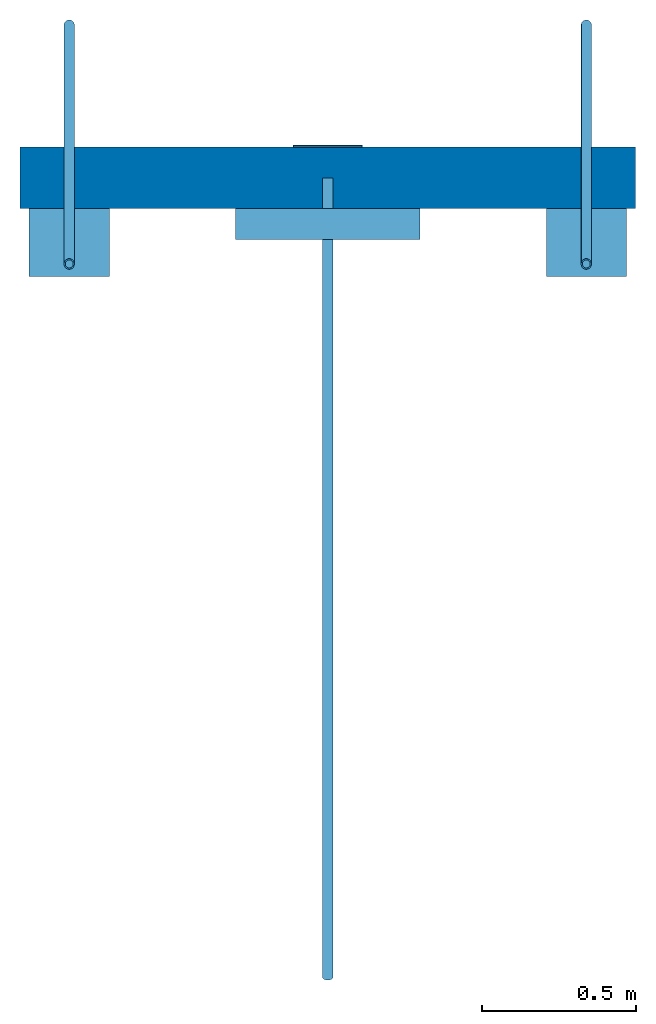
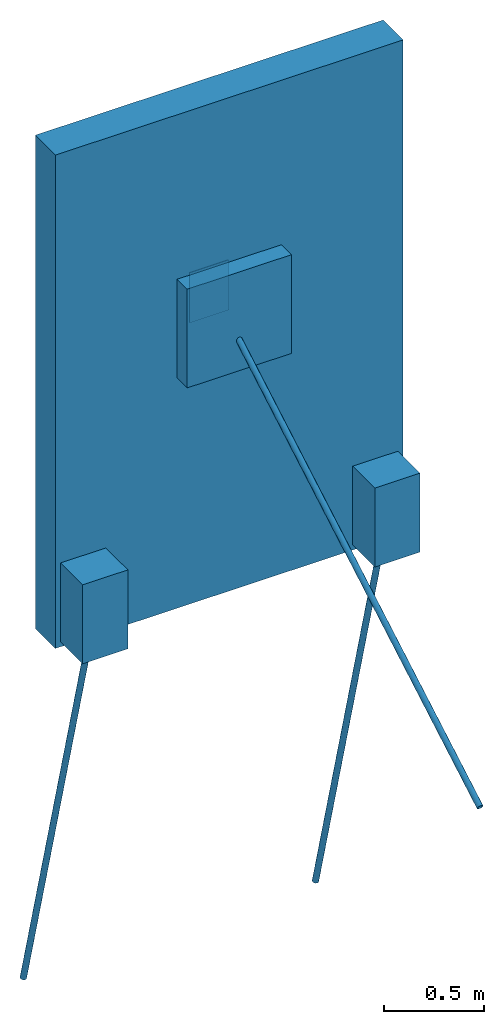
# One storey: 4 walls, 3 beams, 1 column.
"""IFC4 building model written with IfcOpenShell, lengths in metres."""

from ifc_helpers import new_model, entity, si_unit, converted_unit, derived_unit, frame, frame_2d, origin, origin_with_axes, origin_2d_with_axis, place, context, subcontext, project, spatial, polyline, rectangle, outline, extrude, clip, halfspace, material, layer, layer_set, layer_usage, element, save


model = new_model("IFC4")

# Units and contexts
model_context = context("Model", 3, precision=1e-05, world=origin())
body_context = subcontext(model_context, "Body", "Model", "MODEL_VIEW")
ifc_project = project(units=[si_unit("LENGTHUNIT", "METRE"), si_unit("AREAUNIT", "SQUARE_METRE"), si_unit("VOLUMEUNIT", "CUBIC_METRE"), si_unit("MASSUNIT", "GRAM", prefix="KILO"), converted_unit("PLANEANGLEUNIT", "DEGREE", entity("IfcPlaneAngleMeasure", 0.0174532925199433), si_unit("PLANEANGLEUNIT", "RADIAN"), dimensions=[0, 0, 0, 0, 0, 0, 0]), derived_unit("THERMALTRANSMITTANCEUNIT", [(si_unit("POWERUNIT", "WATT"), 1), (si_unit("THERMODYNAMICTEMPERATUREUNIT", "KELVIN"), -1), (si_unit("LENGTHUNIT", "METRE"), -2)]), derived_unit("VOLUMETRICFLOWRATEUNIT", [(si_unit("LENGTHUNIT", "METRE"), 3), (converted_unit("TIMEUNIT", "hour", entity("IfcTimeMeasure", 3600.0), si_unit("TIMEUNIT", "SECOND"), dimensions=[0, 0, 1, 0, 0, 0, 0]), -1), (si_unit("LENGTHUNIT", "METRE"), -1)])], contexts=[model_context])

# Site, building, storey
site_placement = place(None, origin())
site = spatial("IfcSite", under=ifc_project, at=site_placement, CompositionType="ELEMENT")
building_placement = place(site_placement, origin())
building = spatial("IfcBuilding", under=site, at=building_placement, CompositionType="ELEMENT")
storey_placement = place(building_placement, origin())
storey = spatial("IfcBuildingStorey", under=building, at=storey_placement, Name="EG", CompositionType="ELEMENT", Elevation=0.0)

# Column
ifc_material_1 = material(Name="S235")
column_placement = place(storey_placement, frame((-3.53104166666667, -1.190625, 1.5475)))
element("IfcColumn", 1, at=column_placement, inside=storey, material=ifc_material_1, PredefinedType="COLUMN", context=body_context, shape_type="SweptSolid", body=[
    extrude(rectangle(XDim=0.225, YDim=0.006, at=origin_2d_with_axis()), frame((0.1125, 0.003, 0.0), z_axis=(0.0, 0.0, 1.0), x_axis=(1.0, 0.0, 0.0)), (0.0, 0.0, 1.0), 0.305),
])

# Beams
ifc_material_2 = material(Name="S235")
beam_1_placement = place(storey_placement, frame((-3.41854166666667, -1.28221425376656, 1.70485594660196), z_axis=(0.0, 0.0, 1.0), x_axis=(-1.0, 0.0, 0.0)))
element("IfcBeam", 2, at=beam_1_placement, inside=storey, material=ifc_material_2, PredefinedType="BEAM", context=body_context, shape_type="Clipping", body=[
    clip(extrude(outline(polyline([(0.0168499999999999, 0.0), (0.0163958060692701, 0.00388587742201025), (0.0150577099894495, 0.00756226618637811), (0.0129078488665548, 0.0108309712232185), (0.010062122270192, 0.0135157757979227), (0.00667394405775985, 0.0154719414009328), (0.00292597179368784, 0.0165940106382559), (-0.000979740367141517, 0.0168214924668712), (-0.0048326344711819, 0.0161421232825162), (-0.00842499999999996, 0.0145925280537681), (-0.0115631715980882, 0.0122562458605059), (-0.0140779696223079, 0.00925922628049329), (-0.0158338206602425, 0.00576303941503772), (-0.0167360663279518, 0.00195616560301039), (-0.0167360663279518, -0.00195616560300994), (-0.0158338206602425, -0.00576303941503727), (-0.0140779696223079, -0.00925922628049295), (-0.0115631715980882, -0.0122562458605056), (-0.00842499999999996, -0.0145925280537675), (-0.0048326344711819, -0.0161421232825159), (-0.000979740367141517, -0.0168214924668705), (0.00292597179368784, -0.0165940106382554), (0.00667394405775985, -0.0154719414009323), (0.010062122270192, -0.0135157757979223), (0.0129078488665548, -0.0108309712232179), (0.0150577099894495, -0.00756226618637754), (0.0163958060692701, -0.0038858774220098), (0.0168499999999999, 0.0)]), holes=[polyline([(-0.01285, 0.0), (-0.0124121468678145, 0.00332582472956756), (-0.0111284264386301, 0.00642500000000018), (-0.00908632213824717, 0.0090863221382474), (-0.00642499999999996, 0.0111284264386304), (-0.00332582472956744, 0.0124121468678147), (0.0, 0.0128500000000001), (0.00332582472956733, 0.0124121468678147), (0.00642499999999996, 0.0111284264386304), (0.00908632213824717, 0.0090863221382474), (0.0111284264386302, 0.00642500000000018), (0.0124121468678145, 0.00332582472956767), (0.0128499999999999, 0.0), (0.0124121468678145, -0.0033258247295671), (0.0111284264386302, -0.00642499999999973), (0.00908632213824717, -0.00908632213824694), (0.00642499999999996, -0.0111284264386298), (0.00332582472956744, -0.0124121468678143), (0.0, -0.0128499999999998), (-0.00332582472956733, -0.0124121468678144), (-0.00642499999999996, -0.0111284264386298), (-0.00908632213824717, -0.00908632213824694), (-0.0111284264386301, -0.00642499999999973), (-0.0124121468678145, -0.00332582472956722), (-0.01285, 0.0)])]), frame((0.0, 0.0, 0.0), z_axis=(0.0, 0.866025403784439, -0.5), x_axis=(-1.0, 0.0, 0.0)), (0.0, 0.0, 1.0), 3.00971189320392), halfspace(frame((0.0, 0.00841074623343559, -0.00485594660195966), z_axis=(0.0, 1.0, 0.0), x_axis=(1.0, 0.0, 0.0)), True)),
])
ifc_material_3 = material(Name="S235")
beam_2_placement = place(storey_placement, frame((-4.25854166666667, -1.57179157645942, 0.484353722617475)))
element("IfcBeam", 3, at=beam_2_placement, inside=storey, material=ifc_material_3, PredefinedType="BEAM", context=body_context, shape_type="Clipping", body=[
    clip(extrude(outline(polyline([(0.0168499999999999, 0.0), (0.0163958060692701, 0.00388587742201025), (0.0150577099894495, 0.00756226618637811), (0.0129078488665548, 0.0108309712232185), (0.010062122270192, 0.0135157757979227), (0.00667394405775985, 0.0154719414009328), (0.00292597179368784, 0.0165940106382559), (-0.000979740367141517, 0.0168214924668712), (-0.0048326344711819, 0.0161421232825162), (-0.00842499999999996, 0.0145925280537681), (-0.0115631715980882, 0.0122562458605059), (-0.0140779696223079, 0.00925922628049329), (-0.0158338206602425, 0.00576303941503772), (-0.0167360663279518, 0.00195616560301039), (-0.0167360663279518, -0.00195616560300994), (-0.0158338206602425, -0.00576303941503727), (-0.0140779696223079, -0.00925922628049295), (-0.0115631715980882, -0.0122562458605056), (-0.00842499999999996, -0.0145925280537675), (-0.0048326344711819, -0.0161421232825159), (-0.000979740367141517, -0.0168214924668705), (0.00292597179368784, -0.0165940106382554), (0.00667394405775985, -0.0154719414009323), (0.010062122270192, -0.0135157757979223), (0.0129078488665548, -0.0108309712232179), (0.0150577099894495, -0.00756226618637754), (0.0163958060692701, -0.0038858774220098), (0.0168499999999999, 0.0)]), holes=[polyline([(-0.01285, 0.0), (-0.0124121468678145, 0.00332582472956756), (-0.0111284264386301, 0.00642500000000018), (-0.00908632213824717, 0.0090863221382474), (-0.00642499999999996, 0.0111284264386304), (-0.00332582472956744, 0.0124121468678147), (0.0, 0.0128500000000001), (0.00332582472956733, 0.0124121468678147), (0.00642499999999996, 0.0111284264386304), (0.00908632213824717, 0.0090863221382474), (0.0111284264386302, 0.00642500000000018), (0.0124121468678145, 0.00332582472956767), (0.0128499999999999, 0.0), (0.0124121468678145, -0.0033258247295671), (0.0111284264386302, -0.00642499999999973), (0.00908632213824717, -0.00908632213824694), (0.00642499999999996, -0.0111284264386298), (0.00332582472956744, -0.0124121468678143), (0.0, -0.0128499999999998), (-0.00332582472956733, -0.0124121468678144), (-0.00642499999999996, -0.0111284264386298), (-0.00908632213824717, -0.00908632213824694), (-0.0111284264386301, -0.00642499999999973), (-0.0124121468678145, -0.00332582472956722), (-0.01285, 0.0)])]), frame((0.0, 0.0, 0.0), z_axis=(0.0, 0.258819045102521, -0.965925826289068), x_axis=(-1.0, 0.0, 0.0)), (0.0, 0.0, 1.0), 3.00450730532198), halfspace(frame((0.0, 0.00116657645942145, -0.00435372261747467), z_axis=(0.0, 0.0, -1.0), x_axis=(1.0, 0.0, 0.0)), True)),
])
ifc_material_4 = material(Name="S235")
beam_3_placement = place(storey_placement, frame((-2.57854166666667, -1.57179157645942, 0.484353722617475)))
element("IfcBeam", 4, at=beam_3_placement, inside=storey, material=ifc_material_4, PredefinedType="BEAM", context=body_context, shape_type="Clipping", body=[
    clip(extrude(outline(polyline([(0.0168499999999999, 0.0), (0.0163958060692701, 0.00388587742201025), (0.0150577099894495, 0.00756226618637811), (0.0129078488665548, 0.0108309712232185), (0.010062122270192, 0.0135157757979227), (0.00667394405775985, 0.0154719414009328), (0.00292597179368784, 0.0165940106382559), (-0.000979740367141517, 0.0168214924668712), (-0.0048326344711819, 0.0161421232825162), (-0.00842499999999996, 0.0145925280537681), (-0.0115631715980882, 0.0122562458605059), (-0.0140779696223079, 0.00925922628049329), (-0.0158338206602425, 0.00576303941503772), (-0.0167360663279518, 0.00195616560301039), (-0.0167360663279518, -0.00195616560300994), (-0.0158338206602425, -0.00576303941503727), (-0.0140779696223079, -0.00925922628049295), (-0.0115631715980882, -0.0122562458605056), (-0.00842499999999996, -0.0145925280537675), (-0.0048326344711819, -0.0161421232825159), (-0.000979740367141517, -0.0168214924668705), (0.00292597179368784, -0.0165940106382554), (0.00667394405775985, -0.0154719414009323), (0.010062122270192, -0.0135157757979223), (0.0129078488665548, -0.0108309712232179), (0.0150577099894495, -0.00756226618637754), (0.0163958060692701, -0.0038858774220098), (0.0168499999999999, 0.0)]), holes=[polyline([(-0.01285, 0.0), (-0.0124121468678145, 0.00332582472956756), (-0.0111284264386301, 0.00642500000000018), (-0.00908632213824717, 0.0090863221382474), (-0.00642499999999996, 0.0111284264386304), (-0.00332582472956744, 0.0124121468678147), (0.0, 0.0128500000000001), (0.00332582472956733, 0.0124121468678147), (0.00642499999999996, 0.0111284264386304), (0.00908632213824717, 0.0090863221382474), (0.0111284264386302, 0.00642500000000018), (0.0124121468678145, 0.00332582472956767), (0.0128499999999999, 0.0), (0.0124121468678145, -0.0033258247295671), (0.0111284264386302, -0.00642499999999973), (0.00908632213824717, -0.00908632213824694), (0.00642499999999996, -0.0111284264386298), (0.00332582472956744, -0.0124121468678143), (0.0, -0.0128499999999998), (-0.00332582472956733, -0.0124121468678144), (-0.00642499999999996, -0.0111284264386298), (-0.00908632213824717, -0.00908632213824694), (-0.0111284264386301, -0.00642499999999973), (-0.0124121468678145, -0.00332582472956722), (-0.01285, 0.0)])]), frame((0.0, 0.0, 0.0), z_axis=(0.0, 0.258819045102521, -0.965925826289068), x_axis=(-1.0, 0.0, 0.0)), (0.0, 0.0, 1.0), 3.00450730532198), halfspace(frame((0.0, 0.00116657645942145, -0.00435372261747467), z_axis=(0.0, 0.0, -1.0), x_axis=(1.0, 0.0, 0.0)), True)),
])

# Walls
ifc_material_5 = material(Name="Beton")
ifc_layer_1 = layer(ifc_material_5, 0.2)
ifc_layer_set_1 = layer_set([ifc_layer_1])
ifc_layer_usage_1 = layer_usage(ifc_layer_set_1, "AXIS2", "POSITIVE", 0.0)
wall_1_placement = place(storey_placement, frame((-2.41854166666667, -1.190625, 0.0), z_axis=(0.0, 0.0, 1.0), x_axis=(-1.0, 0.0, 0.0)))
element("IfcWall", 5, at=wall_1_placement, inside=storey, material=ifc_layer_usage_1, context=body_context, shape_type="SweptSolid", body=[
    extrude(rectangle(XDim=2.0, YDim=0.2, at=frame_2d((1.0, 0.1), x_axis=(1.0, 0.0))), origin_with_axes(), (0.0, 0.0, 1.0), 3.0),
])
ifc_material_6 = material(Name="Beton")
ifc_layer_2 = layer(ifc_material_6, 0.1)
ifc_layer_set_2 = layer_set([ifc_layer_2])
ifc_layer_usage_2 = layer_usage(ifc_layer_set_2, "AXIS2", "POSITIVE", 0.0)
wall_2_placement = place(storey_placement, frame((-3.11854166666667, -1.390625, 1.4), z_axis=(0.0, 0.0, 1.0), x_axis=(-1.0, 0.0, 0.0)))
element("IfcWall", 6, at=wall_2_placement, inside=storey, material=ifc_layer_usage_2, context=body_context, shape_type="SweptSolid", body=[
    extrude(rectangle(XDim=0.6, YDim=0.1, at=frame_2d((0.3, 0.05), x_axis=(1.0, 0.0))), origin_with_axes(), (0.0, 0.0, 1.0), 0.6),
])
ifc_material_7 = material(Name="Beton")
ifc_layer_3 = layer(ifc_material_7, 0.22)
ifc_layer_set_3 = layer_set([ifc_layer_3])
ifc_layer_usage_3 = layer_usage(ifc_layer_set_3, "AXIS2", "POSITIVE", 0.0)
wall_3_placement = place(storey_placement, frame((-4.12854166666667, -1.390625, 0.03), z_axis=(0.0, 0.0, 1.0), x_axis=(-1.0, 0.0, 0.0)))
element("IfcWall", 7, at=wall_3_placement, inside=storey, material=ifc_layer_usage_3, context=body_context, shape_type="SweptSolid", body=[
    extrude(rectangle(XDim=0.26, YDim=0.22, at=frame_2d((0.13, 0.11), x_axis=(1.0, 0.0))), origin_with_axes(), (0.0, 0.0, 1.0), 0.48),
])
ifc_material_8 = material(Name="Beton")
ifc_layer_4 = layer(ifc_material_8, 0.22)
ifc_layer_set_4 = layer_set([ifc_layer_4])
ifc_layer_usage_4 = layer_usage(ifc_layer_set_4, "AXIS2", "POSITIVE", 0.0)
wall_4_placement = place(storey_placement, frame((-2.44854166666667, -1.390625, 0.03), z_axis=(0.0, 0.0, 1.0), x_axis=(-1.0, 0.0, 0.0)))
element("IfcWall", 8, at=wall_4_placement, inside=storey, material=ifc_layer_usage_4, context=body_context, shape_type="SweptSolid", body=[
    extrude(rectangle(XDim=0.26, YDim=0.22, at=frame_2d((0.13, 0.11), x_axis=(1.0, 0.0))), origin_with_axes(), (0.0, 0.0, 1.0), 0.48),
])

save(model, "model.ifc")
